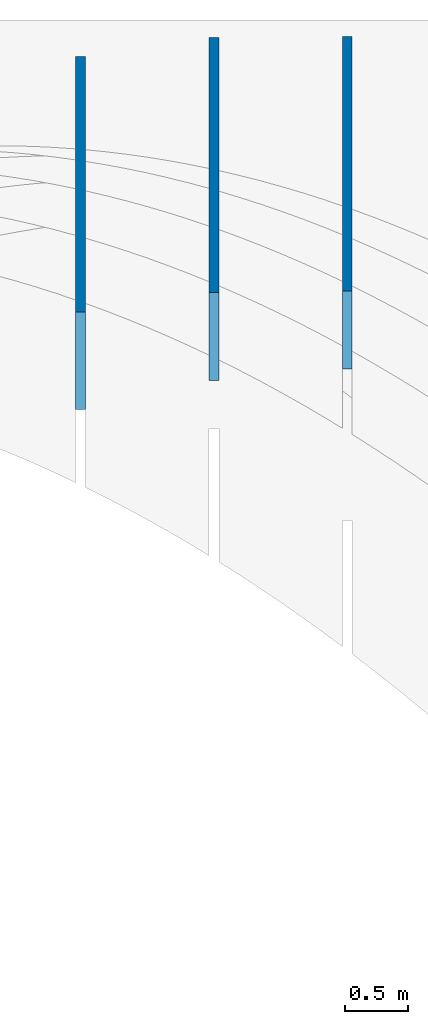
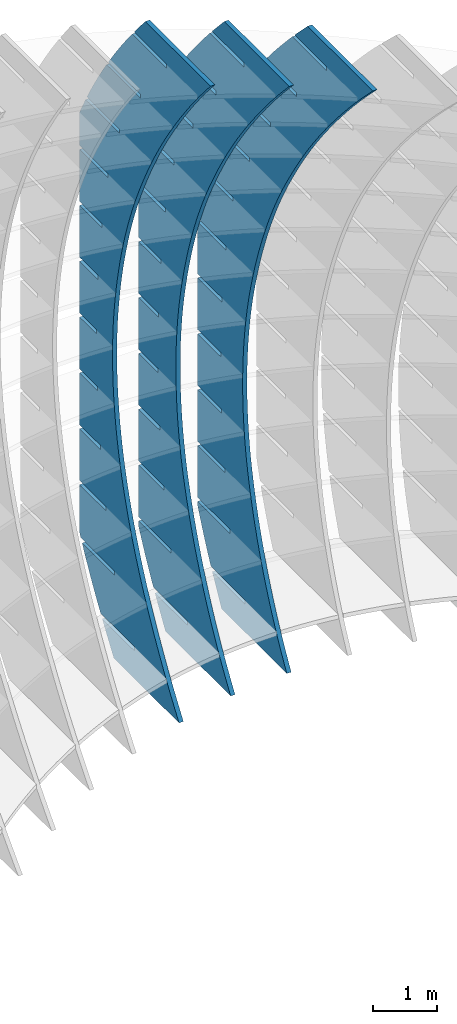
# Not in any storey, part 7 of 9: 3 walls.
"""IFC2X3 building model written with IfcOpenShell, lengths in metres."""

from ifc_helpers import new_model, si_unit, point, direction, frame, frame_2d, origin_with_axes, place, context, project, spatial, polyline, circle_curve, parameter, trimmed, segment, composite_curve, outline, extrude, material, type_object, element, save


model = new_model("IFC2X3")

# Units and contexts
model_context = context("Model", 3, precision=2.54e-06, world=origin_with_axes(), true_north=direction((0.0, 1.0)), identifier="Body")
ifc_project = project(units=[si_unit("LENGTHUNIT", "METRE"), si_unit("AREAUNIT", "SQUARE_METRE"), si_unit("VOLUMEUNIT", "CUBIC_METRE"), si_unit("PLANEANGLEUNIT", "RADIAN")], contexts=[model_context])

# Building
building_placement = place(None, origin_with_axes())
building = spatial("IfcBuilding", under=ifc_project, at=building_placement, Name="Building", CompositionType="ELEMENT")

# Walls
ifc_material = material(Name="MATERIAL")
wall_type = type_object("IfcWallType", Name="WALL", PredefinedType="NOTDEFINED", material=ifc_material)
wall_1_placement = place(None, origin_with_axes())
element("IfcWall", 1, at=wall_1_placement, inside=building, type_object=wall_type, context=model_context, shape_type="SweptSolid", body=[
    extrude(outline(composite_curve([segment(trimmed(circle_curve(frame_2d((0.0, 9.77758385217209), x_axis=(0.0, -1.0)), 9.77758385217209), [parameter(0.0), point((0.0, -9.77758385217209))], [parameter(0.363344617676591), point((3.47497749225876, 0.638345513308649))], True, "PARAMETER"), True, "CONTINUOUS"), segment(trimmed(circle_curve(frame_2d((0.554416200701654, 8.10217493143625), x_axis=(0.36439203, -0.93124564)), 8.0148878869669), [parameter(0.0), point((3.47497749225876, 0.638345513308649))], [parameter(0.382691527800805), point((6.05084574818221, 2.26884911589745))], True, "PARAMETER"), True, "CONTINUOUS"), segment(trimmed(circle_curve(frame_2d((-0.866104227352707, 9.49646196274728), x_axis=(0.69140956, -0.72246303)), 10.0041283692284), [parameter(0.0), point((6.05084574818221, 2.26884911589745))], [parameter(0.329973728158003), point((8.01956013781482, 4.89999013996916))], True, "PARAMETER"), True, "CONTINUOUS"), segment(trimmed(circle_curve(frame_2d((-4.59231375607822, 11.5588003805161), x_axis=(0.88431112, -0.4668981)), 14.2618062297548), [parameter(0.0), point((8.01956013781482, 4.89999013996916))], [parameter(0.129976986192609), point((8.77623463277221, 6.59079968506145))], True, "PARAMETER"), True, "CONTINUOUS"), segment(trimmed(circle_curve(frame_2d((-9.37400391738609, 13.3267514102016), x_axis=(0.93751907, -0.34793389)), 19.3598606676564), [parameter(0.0), point((8.77623463277221, 6.59079968506145))], [parameter(0.123524519316567), point((9.46788051157531, 8.87842630554334))], True, "PARAMETER"), True, "CONTINUOUS"), segment(polyline([(9.46788051157531, 8.87842630554334), (10.5219670849967, 7.14120855991278)]), True, "CONTINUOUS"), segment(polyline([(10.5219670849967, 7.14120855991278), (10.3799879672968, 6.5842631800661)]), True, "CONTINUOUS"), segment(polyline([(10.3799879672968, 6.5842631800661), (9.86260776722556, 7.4369465245508)]), True, "CONTINUOUS"), segment(polyline([(9.86260776722556, 7.4369465245508), (9.79529057958239, 7.39610066983071)]), True, "CONTINUOUS"), segment(polyline([(9.79529057958239, 7.39610066983071), (10.351659705452, 6.47916050291053)]), True, "CONTINUOUS"), segment(trimmed(circle_curve(frame_2d((-7.77534892591131, 11.3871851658596), x_axis=(0.94458906, -0.32825526)), 18.7797004239587), [parameter(0.0700381036296055), point((10.351659705452, 6.47916050291053))], [parameter(0.0), point((9.96375056787807, 5.22264972812563))], False, "PARAMETER"), True, "CONTINUOUS"), segment(polyline([(9.96375056787807, 5.22264972812563), (9.44363244493315, 6.07984538528231)]), True, "CONTINUOUS"), segment(polyline([(9.44363244493315, 6.07984538528231), (9.37631525728998, 6.03899953056222)]), True, "CONTINUOUS"), segment(polyline([(9.37631525728998, 6.03899953056222), (9.92994653329847, 5.1265715559833)]), True, "CONTINUOUS"), segment(trimmed(circle_curve(frame_2d((-4.76274530635075, 10.3258828750832), x_axis=(0.91343543, -0.40698367)), 15.5855071039673), [parameter(0.079030620135602), point((9.92994653329847, 5.1265715559833))], [parameter(0.0), point((9.47360912659921, 3.98283596155331))], False, "PARAMETER"), True, "CONTINUOUS"), segment(polyline([(9.47360912659921, 3.98283596155331), (8.95075804464758, 4.84453575053771)]), True, "CONTINUOUS"), segment(polyline([(8.95075804464758, 4.84453575053771), (8.88344085700441, 4.80368989581763)]), True, "CONTINUOUS"), segment(polyline([(8.88344085700441, 4.80368989581763), (9.43433917400617, 3.89576605306647)]), True, "CONTINUOUS"), segment(trimmed(circle_curve(frame_2d((-2.33999973470338, 9.23656369349782), x_axis=(0.87011595, -0.49284707)), 12.929005227518), [parameter(0.0895181356163678), point((9.43433917400617, 3.89576605306647))], [parameter(0.0), point((8.90973389393647, 2.86454129414623))], False, "PARAMETER"), True, "CONTINUOUS"), segment(polyline([(8.90973389393647, 2.86454129414623), (8.3841498529782, 3.73074521495853)]), True, "CONTINUOUS"), segment(polyline([(8.3841498529782, 3.73074521495853), (8.31683266533503, 3.68989936023844)]), True, "CONTINUOUS"), segment(polyline([(8.31683266533503, 3.68989936023844), (8.86499802333007, 2.78647964931504)]), True, "CONTINUOUS"), segment(trimmed(circle_curve(frame_2d((-0.590325335166754, 8.23762208241438), x_axis=(0.81201666, -0.58363425)), 10.9141235855048), [parameter(0.100224490214003), point((8.86499802333007, 2.78647964931504))], [parameter(0.0), point((8.2721248697741, 1.86776572574387))], False, "PARAMETER"), True, "CONTINUOUS"), segment(polyline([(8.2721248697741, 1.86776572574387), (7.74380787007453, 2.73847377794595)]), True, "CONTINUOUS"), segment(polyline([(7.74380787007453, 2.73847377794595), (7.67649068243136, 2.69762792322587)]), True, "CONTINUOUS"), segment(polyline([(7.67649068243136, 2.69762792322587), (8.22192308115315, 1.79871234456948)]), True, "CONTINUOUS"), segment(polyline([(8.22192308115315, 1.79871234456948), (8.14248313475039, 1.69190338937023)]), True, "CONTINUOUS"), segment(polyline([(8.14248313475039, 1.69190338937023), (7.40714093268338, 1.24572193398344)]), True, "CONTINUOUS"), segment(polyline([(7.40714093268338, 1.24572193398344), (6.94997383991742, 1.9991693322301)]), True, "CONTINUOUS"), segment(polyline([(6.94997383991742, 1.9991693322301), (6.88265665227425, 1.95832347751001)]), True, "CONTINUOUS"), segment(polyline([(6.88265665227425, 1.95832347751001), (7.33982374504021, 1.20487607926335)]), True, "CONTINUOUS"), segment(polyline([(7.33982374504021, 1.20487607926335), (6.49904983837668, 0.694722134240364)]), True, "CONTINUOUS"), segment(polyline([(6.49904983837668, 0.694722134240364), (6.10202350985369, 1.34905281331708)]), True, "CONTINUOUS"), segment(polyline([(6.10202350985369, 1.34905281331708), (6.03470632221052, 1.308206958597)]), True, "CONTINUOUS"), segment(polyline([(6.03470632221052, 1.308206958597), (6.43173265073352, 0.653876279520281)]), True, "CONTINUOUS"), segment(polyline([(6.43173265073352, 0.653876279520281), (5.59095874406999, 0.143722334497295)]), True, "CONTINUOUS"), segment(polyline([(5.59095874406999, 0.143722334497295), (5.21720628409805, 0.759695843986766)]), True, "CONTINUOUS"), segment(polyline([(5.21720628409805, 0.759695843986766), (5.14988909645488, 0.718849989266682)]), True, "CONTINUOUS"), segment(polyline([(5.14988909645488, 0.718849989266682), (5.52364155642682, 0.102876479777211)]), True, "CONTINUOUS"), segment(polyline([(5.52364155642682, 0.102876479777211), (4.6828676497633, -0.407277465245775)]), True, "CONTINUOUS"), segment(polyline([(4.6828676497633, -0.407277465245775), (4.29552216265052, 0.231098424239155)]), True, "CONTINUOUS"), segment(polyline([(4.29552216265052, 0.231098424239155), (4.22820497500735, 0.19025256951907)]), True, "CONTINUOUS"), segment(polyline([(4.22820497500735, 0.19025256951907), (4.61555046212013, -0.448123319965859)]), True, "CONTINUOUS"), segment(polyline([(4.61555046212013, -0.448123319965859), (3.7747765554566, -0.958277264988845)]), True, "CONTINUOUS"), segment(polyline([(3.7747765554566, -0.958277264988845), (3.33697114551109, -0.236739445925754)]), True, "CONTINUOUS"), segment(polyline([(3.33697114551109, -0.236739445925754), (3.26965395786792, -0.277585300645839)]), True, "CONTINUOUS"), segment(polyline([(3.26965395786792, -0.277585300645839), (3.70745936781343, -0.999123119708929)]), True, "CONTINUOUS"), segment(polyline([(3.70745936781343, -0.999123119708929), (2.86668546114991, -1.50927706473192)]), True, "CONTINUOUS"), segment(polyline([(2.86668546114991, -1.50927706473192), (2.34155323267975, -0.643817766507962)]), True, "CONTINUOUS"), segment(polyline([(2.34155323267975, -0.643817766507962), (2.27423604503658, -0.684663621228046)]), True, "CONTINUOUS"), segment(polyline([(2.27423604503658, -0.684663621228046), (2.79936827350676, -1.55012291945204)]), True, "CONTINUOUS"), segment(polyline([(2.79936827350676, -1.55012291945204), (2.7336624435472, -1.58999105534342)]), True, "CONTINUOUS"), segment(trimmed(circle_curve(frame_2d((1.00857875102046, 8.75380998746338), x_axis=(0.07015289, -0.99753625)), 10.4866645678878), [parameter(0.0950431727672252), point((2.7336624435472, -1.58999105534342))], [parameter(0.0), point((1.74424855412249, -1.70701807250379))], False, "PARAMETER"), True, "CONTINUOUS"), segment(polyline([(1.74424855412249, -1.70701807250379), (1.19676286269284, -0.804718505644693)]), True, "CONTINUOUS"), segment(polyline([(1.19676286269284, -0.804718505644693), (1.12944567504967, -0.845564360364778)]), True, "CONTINUOUS"), segment(polyline([(1.12944567504967, -0.845564360364778), (1.65571282438307, -1.71289409761454)]), True, "CONTINUOUS"), segment(polyline([(1.65571282438307, -1.71289409761454), (1.05408657342157, -1.73721774563021)]), True, "CONTINUOUS"), segment(polyline([(1.05408657342157, -1.73721774563021), (0.0, 0.0)]), True, "CONTINUOUS")], self_intersect="UNKNOWN")), frame((15.2120200770936, -0.344273452541799, -6.51240052652897), z_axis=(1.0, 0.0, 0.0), x_axis=(0.0, 0.51874339, 0.85492999)), (0.0, 0.0, 1.0), 0.07874),
])
wall_2_placement = place(None, origin_with_axes())
element("IfcWall", 2, at=wall_2_placement, inside=building, type_object=wall_type, context=model_context, shape_type="SweptSolid", body=[
    extrude(outline(composite_curve([segment(trimmed(circle_curve(frame_2d((0.0, 10.4783041219193), x_axis=(0.0, -1.0)), 10.4783041219193), [parameter(0.0), point((0.0, -10.4783041219193))], [parameter(0.346986254504291), point((3.56330684095518, 0.624487519778126))], True, "PARAMETER"), True, "CONTINUOUS"), segment(trimmed(circle_curve(frame_2d((0.766403700835143, 8.15998171775919), x_axis=(0.34796844, -0.93750625)), 8.03780691376818), [parameter(0.0), point((3.56330684095518, 0.624487519778126))], [parameter(0.381961504920361), point((6.17053898620663, 2.21005215511541))], True, "PARAMETER"), True, "CONTINUOUS"), segment(trimmed(circle_curve(frame_2d((-0.198084874238998, 9.0978224537768), x_axis=(0.67889469, -0.73423565)), 9.38087147140176), [parameter(0.0), point((6.17053898620663, 2.21005215511541))], [parameter(0.344471630373928), point((8.12240375709468, 4.76536143273963))], True, "PARAMETER"), True, "CONTINUOUS"), segment(trimmed(circle_curve(frame_2d((-3.37028301842682, 10.8611866101476), x_axis=(0.88342333, -0.46857574)), 13.0092633885923), [parameter(0.0), point((8.12240375709468, 4.76536143273963))], [parameter(0.138195939837496), point((8.85257337715235, 6.40667031240919))], True, "PARAMETER"), True, "CONTINUOUS"), segment(trimmed(circle_curve(frame_2d((-7.62503133424593, 12.4017312898181), x_axis=(0.93973471, -0.34190448)), 17.5343153030834), [parameter(0.0), point((8.85257337715235, 6.40667031240919))], [parameter(0.131957027131474), point((9.49811857529035, 8.62682065200248))], True, "PARAMETER"), True, "CONTINUOUS"), segment(polyline([(9.49811857529035, 8.62682065200248), (10.6359091557825, 6.9432362035883)]), True, "CONTINUOUS"), segment(polyline([(10.6359091557825, 6.9432362035883), (10.5059679735678, 6.40275859130963)]), True, "CONTINUOUS"), segment(polyline([(10.5059679735678, 6.40275859130963), (9.94602811609891, 7.2312994952732)]), True, "CONTINUOUS"), segment(polyline([(9.94602811609891, 7.2312994952732), (9.88078921872285, 7.18721011027914)]), True, "CONTINUOUS"), segment(polyline([(9.88078921872285, 7.18721011027914), (10.479864094645, 6.30076126650137)]), True, "CONTINUOUS"), segment(trimmed(circle_curve(frame_2d((-5.9926307996587, 10.5382307075286), x_axis=(0.94713685, -0.32082983)), 17.0087987614205), [parameter(0.0748195872683023), point((10.479864094645, 6.30076126650137))], [parameter(0.0), point((10.1170293323872, 5.08130064232984))], False, "PARAMETER"), True, "CONTINUOUS"), segment(polyline([(10.1170293323872, 5.08130064232984), (9.55413413620655, 5.91421454988432)]), True, "CONTINUOUS"), segment(polyline([(9.55413413620655, 5.91421454988432), (9.48889523883048, 5.87012516489025)]), True, "CONTINUOUS"), segment(polyline([(9.48889523883048, 5.87012516489025), (10.0850148548514, 4.98804920808828)]), True, "CONTINUOUS"), segment(trimmed(circle_curve(frame_2d((-3.30986910937848, 9.61610544255414), x_axis=(0.9143599, -0.40490242)), 14.1718672349328), [parameter(0.0842035553852785), point((10.0850148548514, 4.98804920808828))], [parameter(0.0), point((9.6483180000354, 3.87788204484801))], False, "PARAMETER"), True, "CONTINUOUS"), segment(polyline([(9.6483180000354, 3.87788204484801), (9.08247282318637, 4.7151610277187)]), True, "CONTINUOUS"), segment(polyline([(9.08247282318637, 4.7151610277187), (9.0172339258103, 4.67107164272463)]), True, "CONTINUOUS"), segment(polyline([(9.0172339258103, 4.67107164272463), (9.61040356116257, 3.79336076123801)]), True, "CONTINUOUS"), segment(trimmed(circle_curve(frame_2d((-1.18690814447263, 8.66727116329291), x_axis=(0.86835959, -0.4959351)), 11.8463894362758), [parameter(0.0948934978401891), point((9.61040356116257, 3.79336076123801))], [parameter(0.0), point((9.10001774662838, 2.79223087518411))], False, "PARAMETER"), True, "CONTINUOUS"), segment(polyline([(9.10001774662838, 2.79223087518411), (8.53122258925633, 3.63387493315479)]), True, "CONTINUOUS"), segment(polyline([(8.53122258925633, 3.63387493315479), (8.46598369188027, 3.58978554816072)]), True, "CONTINUOUS"), segment(polyline([(8.46598369188027, 3.58978554816072), (9.05620334951691, 2.71643973761979)]), True, "CONTINUOUS"), segment(polyline([(9.05620334951691, 2.71643973761979), (8.99992418931677, 2.62111039313865)]), True, "CONTINUOUS"), segment(polyline([(8.99992418931677, 2.62111039313865), (8.26796748485981, 2.12644352659485)]), True, "CONTINUOUS"), segment(polyline([(8.26796748485981, 2.12644352659485), (7.79439442063361, 2.82718781099074)]), True, "CONTINUOUS"), segment(polyline([(7.79439442063361, 2.82718781099074), (7.72915552325755, 2.78309842599667)]), True, "CONTINUOUS"), segment(polyline([(7.72915552325755, 2.78309842599667), (8.20272858748376, 2.08235414160075)]), True, "CONTINUOUS"), segment(polyline([(8.20272858748376, 2.08235414160075), (7.387911977734, 1.53168935951943)]), True, "CONTINUOUS"), segment(polyline([(7.387911977734, 1.53168935951943), (6.99915262866039, 2.10693510816422)]), True, "CONTINUOUS"), segment(polyline([(6.99915262866039, 2.10693510816422), (6.93391373128432, 2.06284572317015)]), True, "CONTINUOUS"), segment(polyline([(6.93391373128432, 2.06284572317015), (7.32267308035793, 1.48759997452537)]), True, "CONTINUOUS"), segment(polyline([(7.32267308035793, 1.48759997452537), (6.50785647060817, 0.936935192444048)]), True, "CONTINUOUS"), segment(polyline([(6.50785647060817, 0.936935192444048), (6.16411637605375, 1.44556611926903)]), True, "CONTINUOUS"), segment(polyline([(6.16411637605375, 1.44556611926903), (6.09887747867768, 1.40147673427496)]), True, "CONTINUOUS"), segment(polyline([(6.09887747867768, 1.40147673427496), (6.4426175732321, 0.892845807449982)]), True, "CONTINUOUS"), segment(polyline([(6.4426175732321, 0.892845807449982), (5.62780096348234, 0.342181025368664)]), True, "CONTINUOUS"), segment(polyline([(5.62780096348234, 0.342181025368664), (5.28928566281371, 0.843080844305161)]), True, "CONTINUOUS"), segment(polyline([(5.28928566281371, 0.843080844305161), (5.22404676543764, 0.798991459311095)]), True, "CONTINUOUS"), segment(polyline([(5.22404676543764, 0.798991459311095), (5.56256206610628, 0.298091640374598)]), True, "CONTINUOUS"), segment(polyline([(5.56256206610628, 0.298091640374598), (4.74774545635651, -0.252573141706721)]), True, "CONTINUOUS"), segment(polyline([(4.74774545635651, -0.252573141706721), (4.37466048894025, 0.299479283272624)]), True, "CONTINUOUS"), segment(polyline([(4.37466048894025, 0.299479283272624), (4.30942159156419, 0.255389898278558)]), True, "CONTINUOUS"), segment(polyline([(4.30942159156419, 0.255389898278558), (4.68250655898045, -0.296662526700787)]), True, "CONTINUOUS"), segment(polyline([(4.68250655898045, -0.296662526700787), (3.86768994923068, -0.847327308782104)]), True, "CONTINUOUS"), segment(polyline([(3.86768994923068, -0.847327308782104), (3.4202408544334, -0.185238563828584)]), True, "CONTINUOUS"), segment(polyline([(3.4202408544334, -0.185238563828584), (3.35500195705733, -0.229327948822651)]), True, "CONTINUOUS"), segment(polyline([(3.35500195705733, -0.229327948822651), (3.80245105185462, -0.891416693776171)]), True, "CONTINUOUS"), segment(polyline([(3.80245105185462, -0.891416693776171), (2.98763444210485, -1.44208147585749)]), True, "CONTINUOUS"), segment(polyline([(2.98763444210485, -1.44208147585749), (2.42602675929313, -0.611072696998466)]), True, "CONTINUOUS"), segment(polyline([(2.42602675929313, -0.611072696998466), (2.36078786191706, -0.655162081992532)]), True, "CONTINUOUS"), segment(polyline([(2.36078786191706, -0.655162081992532), (2.92239554472879, -1.48617086085156)]), True, "CONTINUOUS"), segment(polyline([(2.92239554472879, -1.48617086085156), (2.83940149569424, -1.54225943265876)]), True, "CONTINUOUS"), segment(trimmed(circle_curve(frame_2d((1.08003107638664, 9.68796289395157), x_axis=(0.06759018, -0.99771317)), 11.3672018446684), [parameter(0.0877590064492989), point((2.83940149569424, -1.54225943265876))], [parameter(0.0), point((1.84834224366087, -1.65324408448214))], False, "PARAMETER"), True, "CONTINUOUS"), segment(polyline([(1.84834224366087, -1.65324408448214), (1.25590624654628, -0.776618764740077)]), True, "CONTINUOUS"), segment(polyline([(1.25590624654628, -0.776618764740077), (1.19066734917021, -0.820708149734144)]), True, "CONTINUOUS"), segment(polyline([(1.19066734917021, -0.820708149734144), (1.75724987937738, -1.65907819159869)]), True, "CONTINUOUS"), segment(polyline([(1.75724987937738, -1.65907819159869), (1.13779058049219, -1.68358444841462)]), True, "CONTINUOUS"), segment(polyline([(1.13779058049219, -1.68358444841462), (0.0, 0.0)]), True, "CONTINUOUS")], self_intersect="UNKNOWN")), frame((14.1498382589117, -0.434574002509988, -6.51240052652903), z_axis=(1.0, 0.0, 0.0), x_axis=(0.0, 0.55993631, 0.82853565)), (0.0, 0.0, 1.0), 0.07874),
])
wall_3_placement = place(None, origin_with_axes())
element("IfcWall", 3, at=wall_3_placement, inside=building, type_object=wall_type, context=model_context, shape_type="SweptSolid", body=[
    extrude(outline(composite_curve([segment(trimmed(circle_curve(frame_2d((0.0, 12.8363073583759), x_axis=(0.0, -1.0)), 12.8363073583759), [parameter(0.0), point((0.0, -12.8363073583759))], [parameter(0.162436309399478), point((2.07592514036361, 0.168974513206732))], True, "PARAMETER"), True, "CONTINUOUS"), segment(trimmed(circle_curve(frame_2d((0.454732054255782, 9.99672628215186), x_axis=(0.16276106, -0.98666551)), 9.96057085986782), [parameter(0.0), point((2.07592514036361, 0.168974513206732))], [parameter(0.165140793065085), point((3.66946517215337, 0.569188807543739))], True, "PARAMETER"), True, "CONTINUOUS"), segment(trimmed(circle_curve(frame_2d((1.05621807864557, 8.30666075273851), x_axis=(0.31998203, -0.94742361)), 8.16685572753694), [parameter(0.0), point((3.66946517215337, 0.569188807543739))], [parameter(0.377915019355546), point((6.34006278381204, 2.07942078577985))], True, "PARAMETER"), True, "CONTINUOUS"), segment(trimmed(circle_curve(frame_2d((0.529134521363277, 8.79535025585699), x_axis=(0.65431662, -0.75622071)), 8.88091188552034), [parameter(0.0), point((6.34006278381204, 2.07942078577985))], [parameter(0.357317947885753), point((8.32201712624219, 4.53605728343164))], True, "PARAMETER"), True, "CONTINUOUS"), segment(trimmed(circle_curve(frame_2d((-2.09803473678749, 10.3197705736069), x_axis=(0.8743426, -0.48530919)), 11.9175844973375), [parameter(0.0), point((8.32201712624219, 4.53605728343164))], [parameter(0.146516332627061), point((9.05475307149666, 6.11927722703835))], True, "PARAMETER"), True, "CONTINUOUS"), segment(trimmed(circle_curve(frame_2d((-5.83372267842013, 11.7154344207229), x_axis=(0.93606063, -0.35183873)), 15.905460870163), [parameter(0.0), point((9.05475307149666, 6.11927722703835))], [parameter(0.140817706450814), point((9.69281657101822, 8.2643093247668))], True, "PARAMETER"), True, "CONTINUOUS"), segment(polyline([(9.69281657101822, 8.2643093247668), (10.8883778023171, 6.62124592300268)]), True, "CONTINUOUS"), segment(polyline([(10.8883778023171, 6.62124592300268), (10.7611291316386, 6.09878028951164)]), True, "CONTINUOUS"), segment(polyline([(10.7611291316386, 6.09878028951164), (10.1712087735189, 6.90950961479157)]), True, "CONTINUOUS"), segment(polyline([(10.1712087735189, 6.90950961479157), (10.1075400667005, 6.86318161707873)]), True, "CONTINUOUS"), segment(polyline([(10.1075400667005, 6.86318161707873), (10.7354827367202, 6.00019811401373)]), True, "CONTINUOUS"), segment(trimmed(circle_curve(frame_2d((-4.19161838580253, 9.90495248377256), x_axis=(0.94418059, -0.32942832)), 15.4293698708071), [parameter(0.0798428635516441), point((10.7354827367202, 6.00019811401373))], [parameter(0.0), point((10.3764931170116, 4.82208106578981))], False, "PARAMETER"), True, "CONTINUOUS"), segment(polyline([(10.3764931170116, 4.82208106578981), (9.78346736458672, 5.6370781438179)]), True, "CONTINUOUS"), segment(polyline([(9.78346736458672, 5.6370781438179), (9.71979865776838, 5.59075014610506)]), True, "CONTINUOUS"), segment(polyline([(9.71979865776838, 5.59075014610506), (10.3446360162951, 4.73203428197956)]), True, "CONTINUOUS"), segment(trimmed(circle_curve(frame_2d((-1.83479986547333, 9.07029635048981), x_axis=(0.90825502, -0.41841705)), 12.9290052275178), [parameter(0.0895181356163691), point((10.3446360162951, 4.73203428197956))], [parameter(0.0), point((9.90803399950838, 3.66058018486513))], False, "PARAMETER"), True, "CONTINUOUS"), segment(polyline([(9.90803399950838, 3.66058018486513), (9.31190848287283, 4.47983727818561)]), True, "CONTINUOUS"), segment(polyline([(9.31190848287283, 4.47983727818561), (9.24823977605449, 4.43350928047278)]), True, "CONTINUOUS"), segment(polyline([(9.24823977605449, 4.43350928047278), (9.86997737037058, 3.57905343163985)]), True, "CONTINUOUS"), segment(polyline([(9.86997737037058, 3.57905343163985), (9.69226767645043, 3.21850851697832)]), True, "CONTINUOUS"), segment(polyline([(9.69226767645043, 3.21850851697832), (9.18478251667053, 2.84924121917278)]), True, "CONTINUOUS"), segment(polyline([(9.18478251667053, 2.84924121917278), (8.66625655673682, 3.56185300795231)]), True, "CONTINUOUS"), segment(polyline([(8.66625655673682, 3.56185300795231), (8.60258784991848, 3.51552501023947)]), True, "CONTINUOUS"), segment(polyline([(8.60258784991848, 3.51552501023947), (9.12111380985219, 2.80291322145995)]), True, "CONTINUOUS"), segment(polyline([(9.12111380985219, 2.80291322145995), (8.32590846574865, 2.22428875735741)]), True, "CONTINUOUS"), segment(polyline([(8.32590846574865, 2.22428875735741), (7.91741008825601, 2.78568930813366)]), True, "CONTINUOUS"), segment(polyline([(7.91741008825601, 2.78568930813366), (7.85374138143767, 2.73936131042083)]), True, "CONTINUOUS"), segment(polyline([(7.85374138143767, 2.73936131042083), (8.26223975893031, 2.17796075964458)]), True, "CONTINUOUS"), segment(polyline([(8.26223975893031, 2.17796075964458), (7.46703441482678, 1.59933629554205)]), True, "CONTINUOUS"), segment(polyline([(7.46703441482678, 1.59933629554205), (7.12674861869374, 2.06699209026761)]), True, "CONTINUOUS"), segment(polyline([(7.12674861869374, 2.06699209026761), (7.0630799118754, 2.02066409255478)]), True, "CONTINUOUS"), segment(polyline([(7.0630799118754, 2.02066409255478), (7.40336570800844, 1.55300829782922)]), True, "CONTINUOUS"), segment(polyline([(7.40336570800844, 1.55300829782922), (6.60816036390491, 0.974383833726685)]), True, "CONTINUOUS"), segment(polyline([(6.60816036390491, 0.974383833726685), (6.29427214805, 1.40576135435415)]), True, "CONTINUOUS"), segment(polyline([(6.29427214805, 1.40576135435415), (6.23060344123166, 1.35943335664132)]), True, "CONTINUOUS"), segment(polyline([(6.23060344123166, 1.35943335664132), (6.54449165708657, 0.92805583601385)]), True, "CONTINUOUS"), segment(polyline([(6.54449165708657, 0.92805583601385), (5.74928631298303, 0.349431371911319)]), True, "CONTINUOUS"), segment(polyline([(5.74928631298303, 0.349431371911319), (5.41998067632479, 0.80199710039328)]), True, "CONTINUOUS"), segment(polyline([(5.41998067632479, 0.80199710039328), (5.35631196950646, 0.755669102680446)]), True, "CONTINUOUS"), segment(polyline([(5.35631196950646, 0.755669102680446), (5.6856176061647, 0.303103374198485)]), True, "CONTINUOUS"), segment(polyline([(5.6856176061647, 0.303103374198485), (4.89041226206116, -0.275521089904046)]), True, "CONTINUOUS"), segment(polyline([(4.89041226206116, -0.275521089904046), (4.50387420351813, 0.255699328385)]), True, "CONTINUOUS"), segment(polyline([(4.50387420351813, 0.255699328385), (4.44020549669979, 0.209371330672166)]), True, "CONTINUOUS"), segment(polyline([(4.44020549669979, 0.209371330672166), (4.82674355524282, -0.321849087616881)]), True, "CONTINUOUS"), segment(polyline([(4.82674355524282, -0.321849087616881), (4.03153821113929, -0.90047355171941)]), True, "CONTINUOUS"), segment(polyline([(4.03153821113929, -0.90047355171941), (3.54595272963, -0.233131961670687)]), True, "CONTINUOUS"), segment(polyline([(3.54595272963, -0.233131961670687), (3.48228402281166, -0.279459959383523)]), True, "CONTINUOUS"), segment(polyline([(3.48228402281166, -0.279459959383523), (3.96786950432095, -0.94680154943226)]), True, "CONTINUOUS"), segment(polyline([(3.96786950432095, -0.94680154943226), (3.23485346277175, -1.48017449186147)]), True, "CONTINUOUS"), segment(polyline([(3.23485346277175, -1.48017449186147), (3.14968098258518, -1.49384016339362)]), True, "CONTINUOUS"), segment(polyline([(3.14968098258518, -1.49384016339362), (2.52875735132363, -0.640502946438585)]), True, "CONTINUOUS"), segment(polyline([(2.52875735132363, -0.640502946438585), (2.46508864450529, -0.68683094415142)]), True, "CONTINUOUS"), segment(polyline([(2.46508864450529, -0.68683094415142), (3.06202812513063, -1.50720667063565)]), True, "CONTINUOUS"), segment(trimmed(circle_curve(frame_2d((1.27071285769937, 10.6514045138625), x_axis=(0.05352079, -0.99856674)), 12.2898590847551), [parameter(0.0927302657431236), point((3.06202812513063, -1.50720667063565))], [parameter(0.0), point((1.92847586503585, -1.62083994871709))], False, "PARAMETER"), True, "CONTINUOUS"), segment(polyline([(1.92847586503585, -1.62083994871709), (1.30440939479865, -0.763183518690405)]), True, "CONTINUOUS"), segment(polyline([(1.30440939479865, -0.763183518690405), (1.24074068798031, -0.809511516403241)]), True, "CONTINUOUS"), segment(polyline([(1.24074068798031, -0.809511516403241), (1.83454123244826, -1.62557339347042)]), True, "CONTINUOUS"), segment(polyline([(1.83454123244826, -1.62557339347042), (1.19556123129923, -1.64306340176358)]), True, "CONTINUOUS"), segment(polyline([(1.19556123129923, -1.64306340176358), (0.0, 0.0)]), True, "CONTINUOUS")], self_intersect="UNKNOWN")), frame((13.0876564407294, -0.66701379214764, -6.51240052652914), z_axis=(1.0, 0.0, 0.0), x_axis=(0.0, 0.58836675, 0.80859419)), (0.0, 0.0, 1.0), 0.07874),
])

save(model, "model.ifc")
